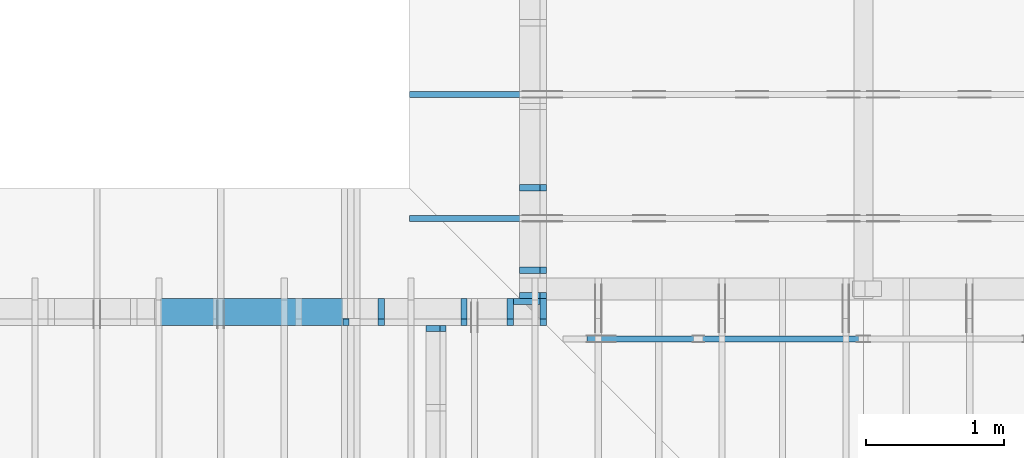
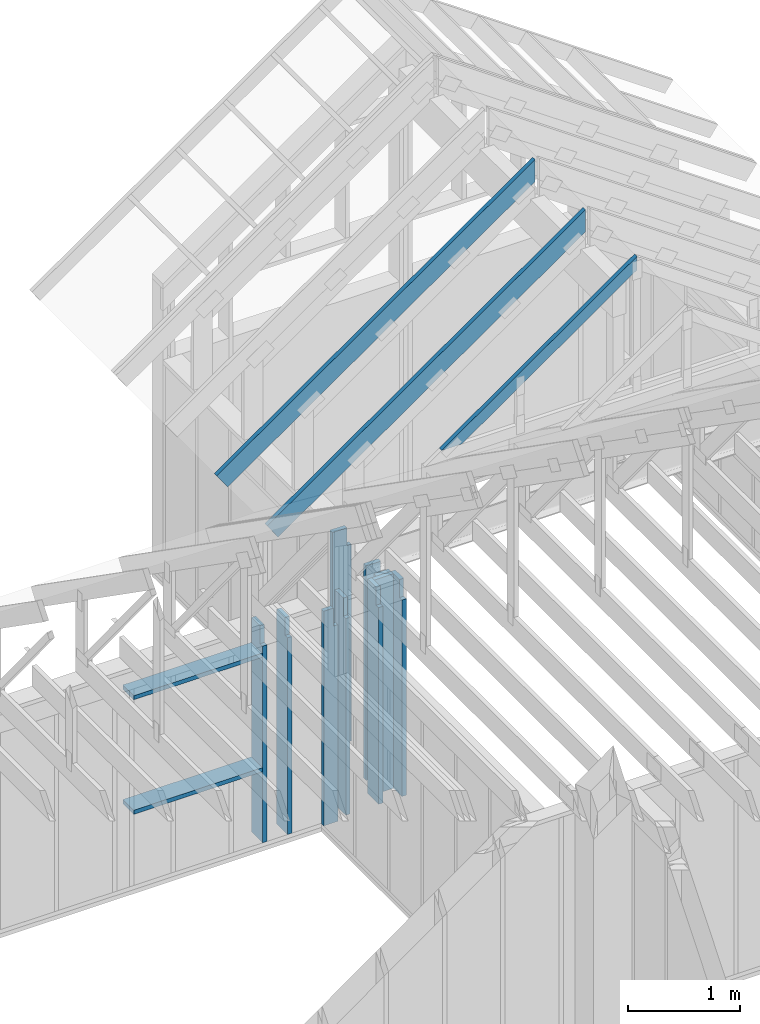
# One storey, part 30 of 70: 15 members, 6 elements without a shape of their own.
"""IFC2X3 building model written with IfcOpenShell, lengths in millimetres."""

from ifc_helpers import new_model, si_unit, frame, origin, origin_with_axes, origin_2d, place, context, project, spatial, faceted_brep, element, aggregate, save


model = new_model("IFC2X3")

# Units and contexts
model_context = context("Model", 3, precision=1e-05, world=origin())
plan_context = context("Plan", 2, precision=1e-05, world=origin_2d())
ifc_project = project(units=[si_unit("LENGTHUNIT", "METRE", prefix="MILLI"), si_unit("AREAUNIT", "SQUARE_METRE"), si_unit("VOLUMEUNIT", "CUBIC_METRE"), si_unit("SOLIDANGLEUNIT", "STERADIAN"), si_unit("PLANEANGLEUNIT", "RADIAN"), si_unit("MASSUNIT", "GRAM"), si_unit("TIMEUNIT", "SECOND"), si_unit("THERMODYNAMICTEMPERATUREUNIT", "DEGREE_CELSIUS"), si_unit("LUMINOUSINTENSITYUNIT", "LUMEN")], contexts=[model_context, plan_context])

# Site, building, storey
site_placement = place(None, origin_with_axes())
site = spatial("IfcSite", under=ifc_project, at=site_placement, CompositionType="ELEMENT")
building_placement = place(site_placement, origin_with_axes())
building = spatial("IfcBuilding", under=site, at=building_placement, Name="Layout 1", CompositionType="ELEMENT")
storey_placement = place(building_placement, origin_with_axes())
storey = spatial("IfcBuildingStorey", under=building, at=storey_placement, Name="Storey 1", CompositionType="ELEMENT", Elevation=0.0)

# Assembly, member
assembly_1_placement = place(storey_placement, frame((7000.0, 9505.0, 1.3776821480501744e-15), z_axis=(1.2246063538223773e-16, 1.0, 6.123031769111886e-17), x_axis=(-1.0, 1.2246063538223773e-16, 0.0)))
assembly_1 = element("IfcElementAssembly", 1, at=assembly_1_placement, inside=storey, Name="T4", AssemblyPlace="FACTORY", PredefinedType="TRUSS")
member_1_placement = place(assembly_1_placement, frame((-2589.347405088728, 2575.029527277477, -45.00000000000001), z_axis=(0.0, 0.0, 1.0), x_axis=(0.8191520442889916, -0.5735764363510465, 0.0)))
member_1 = element("IfcMember", 2, at=member_1_placement, Name="T11", context=model_context, shape_type="Brep", body=[
    faceted_brep([(4001.0887146659597, 194.99999999844545, 45.0), (0.0, 194.99999999844545, 45.0), (136.5404699499495, 1.8338823792873882e-09, 45.0), (4001.0887146652617, 1.8338823792873882e-09, 45.0), (0.0, 194.99999999844545, 0.0), (4001.0887146659597, 194.99999999844545, 4.899758662186943e-13), (4001.0887146652617, 1.8338823792873882e-09, 4.899758662186089e-13), (136.5404699499495, 1.8338823792873882e-09, 1.6720832705460153e-14), (136.54046994994948, 1.8338823792873882e-09, 7.888609052210118e-31), (136.54046994994948, 1.8338823792873882e-09, 45.0), (4.263256414560601e-14, 195.00000000048556, 45.0), (4.263256414560601e-14, 195.00000000048556, -3.1554436208840472e-30), (4001.0887146652617, 2.7584992468545714e-13, -1.6890378523536798e-29), (4001.0887146652617, 2.786052889815575e-13, 45.0), (136.5404699499495, 1.8338945482590892e-09, 45.0), (136.5404699499495, 1.833891792894793e-09, -5.763981720251638e-31), (4001.0887146652617, 194.99999999844545, -4.2712084852286463e-26), (4001.0887146652617, 194.99999999844545, 45.0), (4001.0887146652617, 0.0, 45.0), (4001.0887146652617, 0.0, 0.0), (0.0, 195.00000000048556, 0.0), (0.0, 195.00000000048556, 45.0), (4001.0887146659597, 194.9999999984455, 45.0), (4001.0887146659597, 194.9999999984455, 3.1554436208840472e-30)], [[[0, 1, 2, 3]], [[4, 5, 6, 7]], [[8, 9, 10, 11]], [[12, 13, 14, 15]], [[16, 17, 18, 19]], [[20, 21, 22, 23]]]),
])
aggregate(assembly_1, [member_1])

assembly_2_placement = place(storey_placement, frame((7000.0, 8605.0, 1.3776821480501744e-15), z_axis=(1.2246063538223773e-16, 1.0, 6.123031769111886e-17), x_axis=(-1.0, 1.2246063538223773e-16, 0.0)))
assembly_2 = element("IfcElementAssembly", 3, at=assembly_2_placement, inside=storey, Name="T4", AssemblyPlace="FACTORY", PredefinedType="TRUSS")
member_2_placement = place(assembly_2_placement, frame((-2589.347405088728, 2575.029527277477, -45.00000000000001), z_axis=(0.0, 0.0, 1.0), x_axis=(0.8191520442889916, -0.5735764363510465, 0.0)))
member_2 = element("IfcMember", 4, at=member_2_placement, Name="T11", context=model_context, shape_type="Brep", body=[
    faceted_brep([(4001.0887146659597, 194.99999999844545, 45.0), (0.0, 194.99999999844545, 45.0), (136.5404699499495, 1.8338823792873882e-09, 45.0), (4001.0887146652617, 1.8338823792873882e-09, 45.0), (0.0, 194.99999999844545, 0.0), (4001.0887146659597, 194.99999999844545, 4.899758662186943e-13), (4001.0887146652617, 1.8338823792873882e-09, 4.899758662186089e-13), (136.5404699499495, 1.8338823792873882e-09, 1.6720832705460153e-14), (136.54046994994948, 1.8338823792873882e-09, 7.888609052210118e-31), (136.54046994994948, 1.8338823792873882e-09, 45.0), (4.263256414560601e-14, 195.00000000048556, 45.0), (4.263256414560601e-14, 195.00000000048556, -3.1554436208840472e-30), (4001.0887146652617, 2.7584992468545714e-13, -1.6890378523536798e-29), (4001.0887146652617, 2.786052889815575e-13, 45.0), (136.5404699499495, 1.8338945482590892e-09, 45.0), (136.5404699499495, 1.833891792894793e-09, -5.763981720251638e-31), (4001.0887146652617, 194.99999999844545, -4.2712084852286463e-26), (4001.0887146652617, 194.99999999844545, 45.0), (4001.0887146652617, 0.0, 45.0), (4001.0887146652617, 0.0, 0.0), (0.0, 195.00000000048556, 0.0), (0.0, 195.00000000048556, 45.0), (4001.0887146659597, 194.9999999984455, 45.0), (4001.0887146659597, 194.9999999984455, 3.1554436208840472e-30)], [[[0, 1, 2, 3]], [[4, 5, 6, 7]], [[8, 9, 10, 11]], [[12, 13, 14, 15]], [[16, 17, 18, 19]], [[20, 21, 22, 23]]]),
])
aggregate(assembly_2, [member_2])

# Assembly, members
assembly_3_placement = place(storey_placement, frame((7000.0, 11805.0, -2470.0), z_axis=(-1.0, 1.836909530733566e-16, 6.123031769111886e-17), x_axis=(-1.836909530733566e-16, -1.0, 0.0)))
assembly_3 = element("IfcElementAssembly", 5, at=assembly_3_placement, inside=storey, Name="VE1", AssemblyPlace="FACTORY", PredefinedType="NOTDEFINED")
member_3_placement = place(assembly_3_placement, frame((3759.9999999962747, 2425.0, -195.00000000000003), z_axis=(0.0, 0.0, 1.0), x_axis=(-1.836909530733566e-16, -1.0, 0.0)))
member_3 = element("IfcMember", 6, at=member_3_placement, Name="S11", context=model_context, shape_type="Brep", body=[
    faceted_brep([(0.0, 45.0, 45.00000000000003), (195.00000000186265, 45.0, 45.00000000000005), (195.00000000186265, 0.0, 45.00000000000005), (0.0, 0.0, 45.00000000000003), (195.00000000186265, 1.5552359400317073e-10, 2.842170943040401e-14), (195.00000000186265, 1.5552359400317073e-10, 45.00000000000003), (195.00000000186265, 45.000000000155524, 45.00000000000003), (195.00000000186265, 45.000000000155524, 2.842170943040401e-14), (2.7553642961003504e-15, -3.3742366240998114e-31, 45.00000000000003), (1.193991194976818e-14, -1.4621692037765842e-30, 195.00000000000003), (1.7450640541968876e-14, 45.0, 195.00000000000003), (8.266092888301048e-15, 45.0, 45.00000000000003), (2335.0, -4.2891837542628763e-13, 2.842170943040403e-14), (2335.0, -4.1697846347651946e-13, 195.00000000000003), (2.1932538056648764e-30, 1.193991194976818e-14, 195.00000000000003), (5.061354936149717e-31, 2.7553642961003504e-15, 45.00000000000003), (195.00000000186265, -3.306437155354634e-14, 45.00000000000003), (195.00000000186265, -3.5819735849646686e-14, 2.842170943040401e-14), (-1.6871183120499057e-31, 45.000000000155524, 45.00000000000003), (-7.310846018882921e-31, 45.00000000015551, 195.00000000000003), (2335.0, 45.00000000015537, 195.00000000000003), (2335.0, 45.00000000015538, 2.8421709430403998e-14), (195.00000000186265, 45.00000000015551, 2.842170943040401e-14), (195.00000000186265, 45.00000000015551, 45.00000000000003), (2335.0, 45.0000000018631, 0.0), (2335.0, 45.0000000018631, 195.00000000000003), (2335.0, 1.8630998965818435e-09, 195.00000000000003), (2335.0, 1.8630998965818435e-09, 0.0), (2335.0, 45.0000000018631, 195.00000000000003), (0.0, 45.0000000018631, 195.00000000000003), (0.0, 0.0, 195.00000000000003), (2335.0, 0.0, 195.00000000000003), (195.00000000186265, 45.000000000155524, 5.2301533330168465e-14), (2335.0, 45.000000000155524, 3.143672930479291e-13), (2335.0, 1.8630998965818435e-09, 3.143672930479291e-13), (195.00000000186265, 1.8630998965818435e-09, 5.2301533330168465e-14)], [[[0, 1, 2, 3]], [[4, 5, 6, 7]], [[8, 9, 10, 11]], [[12, 13, 14, 15, 16, 17]], [[18, 19, 20, 21, 22, 23]], [[24, 25, 26, 27]], [[28, 29, 30, 31]], [[32, 33, 34, 35]]]),
])
member_4_placement = place(assembly_3_placement, frame((3577.5000000036816, 2425.0, -195.00000000000003), z_axis=(0.0, 0.0, 1.0), x_axis=(-1.836909530733566e-16, -1.0, 0.0)))
member_4 = element("IfcMember", 7, at=member_4_placement, Name="S11", context=model_context, shape_type="Brep", body=[
    faceted_brep([(0.0, 45.0, 45.00000000000003), (195.00000000186265, 45.0, 45.00000000000005), (195.00000000186265, 0.0, 45.00000000000005), (0.0, 0.0, 45.00000000000003), (195.00000000186265, -2.1311460639909362e-46, 2.842170943040401e-14), (195.00000000186265, -3.3742366240998114e-31, 45.00000000000003), (195.00000000186265, 45.0, 45.00000000000003), (195.00000000186265, 45.0, 2.842170943040401e-14), (2.7553642961003504e-15, -3.3742366240998114e-31, 45.00000000000003), (1.193991194976818e-14, -1.4621692037765842e-30, 195.00000000000003), (1.7450640541968876e-14, 45.0, 195.00000000000003), (8.266092888301048e-15, 45.0, 45.00000000000003), (2335.0, -4.2891837542628763e-13, 2.842170943040403e-14), (2335.0, -4.1697846347651946e-13, 195.00000000000003), (2.1932538056648764e-30, 1.193991194976818e-14, 195.00000000000003), (5.061354936149717e-31, 2.7553642961003504e-15, 45.00000000000003), (195.00000000186265, -3.306437155354634e-14, 45.00000000000003), (195.00000000186265, -3.5819735849646686e-14, 2.842170943040401e-14), (-1.6871183120499057e-31, 45.0, 45.00000000000003), (-7.310846018882921e-31, 44.999999999999986, 195.00000000000003), (2335.0, 44.999999999999844, 195.00000000000003), (2335.0, 44.99999999999986, 2.8421709430403998e-14), (195.00000000186265, 44.999999999999986, 2.842170943040401e-14), (195.00000000186265, 44.999999999999986, 45.00000000000003), (2335.0, 45.000000000000455, 0.0), (2335.0, 45.000000000000455, 195.00000000000003), (2335.0, 4.547473508864641e-13, 195.00000000000003), (2335.0, 4.547473508864641e-13, 0.0), (2335.0, 45.000000000000455, 195.00000000000003), (0.0, 45.000000000000455, 195.00000000000003), (0.0, 0.0, 195.00000000000003), (2335.0, 0.0, 195.00000000000003), (195.00000000186265, 45.0, 5.2301533330168465e-14), (2335.0, 45.0, 3.143672930479291e-13), (2335.0, 4.547473508864641e-13, 3.143672930479291e-13), (195.00000000186265, 4.547473508864641e-13, 5.2301533330168465e-14)], [[[0, 1, 2, 3]], [[4, 5, 6, 7]], [[8, 9, 10, 11]], [[12, 13, 14, 15, 16, 17]], [[18, 19, 20, 21, 22, 23]], [[24, 25, 26, 27]], [[28, 29, 30, 31]], [[32, 33, 34, 35]]]),
])
member_5_placement = place(assembly_3_placement, frame((2977.5000000036816, 2425.0, -195.00000000000003), z_axis=(0.0, 0.0, 1.0), x_axis=(-1.836909530733566e-16, -1.0, 0.0)))
member_5 = element("IfcMember", 8, at=member_5_placement, Name="S11", context=model_context, shape_type="Brep", body=[
    faceted_brep([(0.0, 45.0, 45.00000000000003), (195.00000000186265, 45.0, 45.00000000000005), (195.00000000186265, 0.0, 45.00000000000005), (0.0, 0.0, 45.00000000000003), (195.00000000186265, -2.1311460639909362e-46, 2.842170943040401e-14), (195.00000000186265, -3.3742366240998114e-31, 45.00000000000003), (195.00000000186265, 45.0, 45.00000000000003), (195.00000000186265, 45.0, 2.842170943040401e-14), (2.7553642961003504e-15, -3.3742366240998114e-31, 45.00000000000003), (1.193991194976818e-14, -1.4621692037765842e-30, 195.00000000000003), (1.7450640541968876e-14, 45.0, 195.00000000000003), (8.266092888301048e-15, 45.0, 45.00000000000003), (2335.0, -4.2891837542628763e-13, 2.842170943040403e-14), (2335.0, -4.1697846347651946e-13, 195.00000000000003), (2.1932538056648764e-30, 1.193991194976818e-14, 195.00000000000003), (5.061354936149717e-31, 2.7553642961003504e-15, 45.00000000000003), (195.00000000186265, -3.306437155354634e-14, 45.00000000000003), (195.00000000186265, -3.5819735849646686e-14, 2.842170943040401e-14), (-1.6871183120499057e-31, 45.0, 45.00000000000003), (-7.310846018882921e-31, 44.999999999999986, 195.00000000000003), (2335.0, 44.999999999999844, 195.00000000000003), (2335.0, 44.99999999999986, 2.8421709430403998e-14), (195.00000000186265, 44.999999999999986, 2.842170943040401e-14), (195.00000000186265, 44.999999999999986, 45.00000000000003), (2335.0, 45.000000000000455, 0.0), (2335.0, 45.000000000000455, 195.00000000000003), (2335.0, 4.547473508864641e-13, 195.00000000000003), (2335.0, 4.547473508864641e-13, 0.0), (2335.0, 45.000000000000455, 195.00000000000003), (0.0, 45.000000000000455, 195.00000000000003), (0.0, 0.0, 195.00000000000003), (2335.0, 0.0, 195.00000000000003), (195.00000000186265, 45.0, 5.2301533330168465e-14), (2335.0, 45.0, 3.143672930479291e-13), (2335.0, 4.547473508864641e-13, 3.143672930479291e-13), (195.00000000186265, 4.547473508864641e-13, 5.2301533330168465e-14)], [[[0, 1, 2, 3]], [[4, 5, 6, 7]], [[8, 9, 10, 11]], [[12, 13, 14, 15, 16, 17]], [[18, 19, 20, 21, 22, 23]], [[24, 25, 26, 27]], [[28, 29, 30, 31]], [[32, 33, 34, 35]]]),
])
aggregate(assembly_3, [member_3, member_4, member_5])

assembly_4_placement = place(storey_placement, frame((6999.999999999999, 8000.0, -2470.0), z_axis=(1.2246063538223773e-16, 1.0, 6.123031769111886e-17), x_axis=(-1.0, 1.2246063538223773e-16, 0.0)))
assembly_4 = element("IfcElementAssembly", 9, at=assembly_4_placement, inside=storey, Name="VE2", AssemblyPlace="FACTORY", PredefinedType="NOTDEFINED")
member_6_placement = place(assembly_4_placement, frame((-150.0, 90.00000000000088, -195.00000000000003), z_axis=(0.0, 0.0, 1.0), x_axis=(6.123031769111886e-17, 1.0, 0.0)))
member_6 = element("IfcMember", 10, at=member_6_placement, Name="S11", context=model_context, shape_type="Brep", body=[
    faceted_brep([(2139.9999999981364, 45.00000000000014, 2.842170943040401e-14), (2139.9999999981364, 45.00000000000014, 45.00000000000003), (2139.9999999981364, 1.4210854715202004e-13, 45.00000000000003), (2139.9999999981364, 1.4210854715202004e-13, 2.842170943040401e-14), (2139.9999999981364, 45.00000000000014, 45.00000000000029), (2334.999999999999, 45.00000000000014, 45.00000000000031), (2334.999999999999, 1.4210854715202004e-13, 45.00000000000031), (2139.9999999981364, 1.4210854715202004e-13, 45.00000000000029), (2.842170943040401e-14, 45.00000000000014, 2.842170943040401e-14), (2.842170943040401e-14, 45.00000000000013, 195.00000000000003), (2334.999999999999, 44.999999999999986, 195.00000000000003), (2334.999999999999, 44.99999999999999, 45.00000000000003), (2139.9999999981364, 45.00000000000001, 45.00000000000003), (2139.9999999981364, 45.000000000000014, 2.8421709430404e-14), (2.842170943040401e-14, 45.0, 2.8421709430404014e-14), (2139.9999999981364, 45.0, 2.9048746914816454e-13), (2139.9999999981364, 1.4210854715202004e-13, 2.9048746914816454e-13), (2.842170943040401e-14, 1.4210854715202004e-13, 2.8421709430404014e-14), (2.842170943040401e-14, 0.0, 0.0), (-2.9370765802089257e-15, 1.7766315360985582e-29, 195.00000000000003), (2.255766645524459e-14, 45.0, 195.00000000000003), (5.391645246585752e-14, 45.0, -4.7069801456157764e-31), (2334.999999999999, -2.840544639781671e-13, 45.00000000000003), (2334.999999999999, -2.7486991632449927e-13, 195.00000000000003), (2.842170943040401e-14, 1.5404845910178822e-13, 195.00000000000003), (2.842170943040401e-14, 1.4210854715202004e-13, 2.8421709430404004e-14), (2139.9999999981364, -2.5099009242462076e-13, 2.842170943040403e-14), (2139.9999999981364, -2.482347281285204e-13, 45.00000000000003), (2334.999999999999, 45.00000000000014, 45.00000000000003), (2334.999999999999, 45.00000000000014, 195.00000000000003), (2334.999999999999, 1.4210854715202004e-13, 195.00000000000003), (2334.999999999999, 1.4210854715202004e-13, 45.00000000000003), (2334.999999999999, 45.00000000000014, 195.00000000000003), (2.842170943040401e-14, 45.00000000000014, 195.00000000000003), (2.842170943040401e-14, 0.0, 195.00000000000003), (2334.999999999999, 0.0, 195.00000000000003)], [[[0, 1, 2, 3]], [[4, 5, 6, 7]], [[8, 9, 10, 11, 12, 13]], [[14, 15, 16, 17]], [[18, 19, 20, 21]], [[22, 23, 24, 25, 26, 27]], [[28, 29, 30, 31]], [[32, 33, 34, 35]]]),
])
member_7_placement = place(assembly_4_placement, frame((90.0, 90.0, -195.00000000000003), z_axis=(0.0, 0.0, 1.0), x_axis=(6.123031769111886e-17, 1.0, 0.0)))
member_7 = element("IfcMember", 11, at=member_7_placement, Name="S11", context=model_context, shape_type="Brep", body=[
    faceted_brep([(2139.9999999981374, 45.000000000000135, 2.842170943040401e-14), (2139.9999999981374, 45.000000000000135, 45.00000000000003), (2139.9999999981374, 1.4210854715202004e-13, 45.00000000000003), (2139.9999999981374, 1.4210854715202004e-13, 2.842170943040401e-14), (2139.9999999981374, 45.000000000000135, 45.00000000000029), (2335.0, 45.000000000000135, 45.00000000000031), (2335.0, 1.4210854715202004e-13, 45.00000000000031), (2139.9999999981374, 1.4210854715202004e-13, 45.00000000000029), (-1.0655730319954681e-46, 45.00000000000015, 2.842170943040401e-14), (-7.310846018882921e-31, 45.000000000000135, 195.00000000000003), (2335.0, 44.99999999999999, 195.00000000000003), (2335.0, 45.0, 45.00000000000003), (2139.9999999981374, 45.000000000000014, 45.00000000000003), (2139.9999999981374, 45.00000000000002, 2.8421709430404e-14), (0.0, 45.00000000000001, 2.842170943040401e-14), (2139.9999999981374, 45.00000000000001, 2.9048746914816464e-13), (2139.9999999981374, 1.4210854715202004e-13, 2.9048746914816464e-13), (0.0, 1.4210854715202004e-13, 2.842170943040401e-14), (0.0, 0.0, 0.0), (1.193991194976818e-14, -1.4621692037765842e-30, 195.00000000000003), (1.745064054196888e-14, 45.000000000000014, 195.00000000000003), (5.510728592200699e-15, 45.000000000000014, -3.37423662409981e-31), (2335.0, -1.2809944300270402e-13, 45.00000000000003), (2335.0, -1.189148953490362e-13, 195.00000000000003), (3.3451185691845497e-29, 3.1000348007725144e-13, 195.00000000000003), (3.125793188618062e-29, 2.9806356812748326e-13, 2.8421709430403995e-14), (2139.9999999981374, -9.503507144915769e-14, 2.842170943040402e-14), (2139.9999999981374, -9.227970715305734e-14, 45.00000000000003), (2335.0, 45.000000000000156, 45.00000000000003), (2335.0, 45.000000000000156, 195.00000000000003), (2335.0, 1.4210854715202004e-13, 195.00000000000003), (2335.0, 1.4210854715202004e-13, 45.00000000000003), (2335.0, 45.00000000000015, 195.00000000000003), (0.0, 45.00000000000015, 195.00000000000003), (0.0, 0.0, 195.00000000000003), (2335.0, 0.0, 195.00000000000003)], [[[0, 1, 2, 3]], [[4, 5, 6, 7]], [[8, 9, 10, 11, 12, 13]], [[14, 15, 16, 17]], [[18, 19, 20, 21]], [[22, 23, 24, 25, 26, 27]], [[28, 29, 30, 31]], [[32, 33, 34, 35]]]),
])
member_8_placement = place(assembly_4_placement, frame((45.0, 89.99999999999999, -45.0), z_axis=(0.0, 0.0, 1.0), x_axis=(6.123031769111886e-17, 1.0, 0.0)))
member_8 = element("IfcMember", 12, at=member_8_placement, Name="S34", context=model_context, shape_type="Brep", body=[
    faceted_brep([(2335.0, 195.00000000000014, 45.0), (0.0, 195.00000000000014, 45.0), (1.4210854715202004e-14, 0.0, 45.0), (2335.0, 0.0, 45.0), (0.0, 195.00000000000014, 0.0), (2335.0, 195.00000000000014, 2.859455836175251e-13), (2335.0, 0.0, 2.859455836175251e-13), (1.4210854715202004e-14, 0.0, 1.7402702977483063e-30), (1.4210854715202004e-14, 0.0, 0.0), (1.6966219011302353e-14, -3.3742366240998092e-31, 45.0), (4.084604291083871e-14, 195.0, 45.0), (3.809067861473836e-14, 195.0, -2.332304352650737e-30), (2335.0, -4.2891837542628763e-13, 3.4964159879651713e-29), (2335.0, -4.261630111301873e-13, 45.0), (1.4210854715202004e-14, 2.7553642961003453e-15, 45.0), (1.4210854715202004e-14, -3.4752807859654105e-30, 2.1279254659050334e-46), (2335.0, 195.00000000000014, 0.0), (2335.0, 195.00000000000014, 45.0), (2335.0, 1.4210854715202004e-13, 45.0), (2335.0, 1.4210854715202004e-13, 0.0), (0.0, 195.0, 0.0), (0.0, 195.0, 45.0), (2335.0, 195.00000000000037, 45.0), (2335.0, 195.00000000000037, 1.4199496293978212e-29)], [[[0, 1, 2, 3]], [[4, 5, 6, 7]], [[8, 9, 10, 11]], [[12, 13, 14, 15]], [[16, 17, 18, 19]], [[20, 21, 22, 23]]]),
])
member_9_placement = place(assembly_4_placement, frame((382.50000000181944, 2425.0, -195.0), z_axis=(0.0, 0.0, 1.0), x_axis=(-1.836909530733566e-16, -1.0, 0.0)))
member_9 = element("IfcMember", 13, at=member_9_placement, Name="S11", context=model_context, shape_type="Brep", body=[
    faceted_brep([(0.0, 45.0000000000141, 45.0), (195.00000000186265, 45.0000000000141, 45.00000000000002), (195.00000000186265, 1.4097167877480388e-11, 45.00000000000002), (0.0, 1.4097167877480388e-11, 45.0), (195.00000000186265, 1.2960299500264227e-11, 0.0), (195.00000000186265, 1.2960299500264227e-11, 45.0), (195.00000000186265, 45.000000000014154, 45.0), (195.00000000186265, 45.000000000014154, 0.0), (2.7553642961020753e-15, 1.4097167877480388e-11, 45.0), (1.1939911949769904e-14, 1.4097167877480388e-11, 195.0), (1.7450640541970602e-14, 45.0000000000141, 195.0), (8.266092888302773e-15, 45.0000000000141, 45.0), (2335.0, 1.36682495020541e-11, 2.626280839091018e-29), (2335.0, 1.3680189414003868e-11, 195.0), (2.193253805664876e-30, 1.4109107789430156e-11, 195.0), (5.061354936149714e-31, 1.4099923241776488e-11, 45.0), (195.00000000186265, 1.4064103505926841e-11, 45.0), (195.00000000186265, 1.406134814163074e-11, 2.193253805685862e-30), (-1.6871183120499046e-31, 45.000000000014154, 45.0), (-7.31084601888292e-31, 45.00000000001414, 195.0), (2335.0, 45.000000000014, 195.0), (2335.0, 45.00000000001401, -8.67746995743113e-30), (195.00000000186265, 45.00000000001414, -7.888609052210118e-31), (195.00000000186265, 45.00000000001414, 45.0), (2335.0, 45.00000000001455, 0.0), (2335.0, 45.00000000001455, 195.0), (2335.0, 0.0, 195.0), (2335.0, 0.0, 0.0), (2335.0, 45.00000000001455, 195.0), (0.0, 45.00000000001455, 195.0), (0.0, 1.4097167877480388e-11, 195.0), (2335.0, 1.4097167877480388e-11, 195.0), (195.00000000186265, 45.000000000014154, 2.3879823899764457e-14), (2335.0, 45.000000000014154, 2.859455836175251e-13), (2335.0, 0.0, 2.859455836175251e-13), (195.00000000186265, 0.0, 2.3879823899764457e-14)], [[[0, 1, 2, 3]], [[4, 5, 6, 7]], [[8, 9, 10, 11]], [[12, 13, 14, 15, 16, 17]], [[18, 19, 20, 21, 22, 23]], [[24, 25, 26, 27]], [[28, 29, 30, 31]], [[32, 33, 34, 35]]]),
])
member_10_placement = place(assembly_4_placement, frame((982.5000000018194, 2425.0, -195.0), z_axis=(0.0, 0.0, 1.0), x_axis=(-1.836909530733566e-16, -1.0, 0.0)))
member_10 = element("IfcMember", 14, at=member_10_placement, Name="S11", context=model_context, shape_type="Brep", body=[
    faceted_brep([(0.0, 45.0000000000141, 45.0), (195.00000000186265, 45.0000000000141, 45.00000000000002), (195.00000000186265, 1.4097167877480388e-11, 45.00000000000002), (0.0, 1.4097167877480388e-11, 45.0), (195.00000000186265, 1.2846612662542611e-11, 0.0), (195.00000000186265, 1.2846612662542611e-11, 45.0), (195.00000000186265, 45.0000000000141, 45.0), (195.00000000186265, 45.0000000000141, 0.0), (2.7553642961020753e-15, 1.4097167877480388e-11, 45.0), (1.1939911949769904e-14, 1.4097167877480388e-11, 195.0), (1.7450640541970602e-14, 45.0000000000141, 195.0), (8.266092888302773e-15, 45.0000000000141, 45.0), (2335.0, 1.36682495020541e-11, 2.626280839091018e-29), (2335.0, 1.3680189414003868e-11, 195.0), (2.193253805664876e-30, 1.4109107789430156e-11, 195.0), (5.061354936149714e-31, 1.4099923241776488e-11, 45.0), (195.00000000186265, 1.4064103505926841e-11, 45.0), (195.00000000186265, 1.406134814163074e-11, 2.193253805685862e-30), (-1.6871183120499046e-31, 45.0000000000141, 45.0), (-7.31084601888292e-31, 45.00000000001408, 195.0), (2335.0, 45.00000000001394, 195.0), (2335.0, 45.000000000013955, -8.67746995743113e-30), (195.00000000186265, 45.00000000001408, -7.888609052210118e-31), (195.00000000186265, 45.00000000001408, 45.0), (2335.0, 45.00000000001455, 0.0), (2335.0, 45.00000000001455, 195.0), (2335.0, 0.0, 195.0), (2335.0, 0.0, 0.0), (2335.0, 45.00000000001455, 195.0), (0.0, 45.00000000001455, 195.0), (0.0, 1.4097167877480388e-11, 195.0), (2335.0, 1.4097167877480388e-11, 195.0), (195.00000000186265, 45.0000000000141, 2.3879823899764457e-14), (2335.0, 45.0000000000141, 2.859455836175251e-13), (2335.0, 0.0, 2.859455836175251e-13), (195.00000000186265, 0.0, 2.3879823899764457e-14)], [[[0, 1, 2, 3]], [[4, 5, 6, 7]], [[8, 9, 10, 11]], [[12, 13, 14, 15, 16, 17]], [[18, 19, 20, 21, 22, 23]], [[24, 25, 26, 27]], [[28, 29, 30, 31]], [[32, 33, 34, 35]]]),
])
member_11_placement = place(assembly_4_placement, frame((1240.0000000015425, 2425.0, -195.00000000000003), z_axis=(0.0, 0.0, 1.0), x_axis=(-1.836909530733566e-16, -1.0, 0.0)))
member_11 = element("IfcMember", 15, at=member_11_placement, Name="S11", context=model_context, shape_type="Brep", body=[
    faceted_brep([(0.0, 45.0, 45.00000000000003), (195.00000000186265, 45.0, 45.00000000000005), (195.00000000186265, 0.0, 45.00000000000005), (0.0, 0.0, 45.00000000000003), (195.00000000186265, -2.1311460639909362e-46, 2.842170943040401e-14), (195.00000000186265, -3.3742366240998114e-31, 45.00000000000003), (195.00000000186265, 45.0, 45.00000000000003), (195.00000000186265, 45.0, 2.842170943040401e-14), (2.7553642961003504e-15, -3.3742366240998114e-31, 45.00000000000003), (1.193991194976818e-14, -1.4621692037765842e-30, 195.00000000000003), (1.7450640541968876e-14, 45.0, 195.00000000000003), (8.266092888301048e-15, 45.0, 45.00000000000003), (2335.0, -4.2891837542628763e-13, 2.842170943040403e-14), (2335.0, -4.1697846347651946e-13, 195.00000000000003), (2.1932538056648764e-30, 1.193991194976818e-14, 195.00000000000003), (5.061354936149717e-31, 2.7553642961003504e-15, 45.00000000000003), (195.00000000186265, -3.306437155354634e-14, 45.00000000000003), (195.00000000186265, -3.5819735849646686e-14, 2.842170943040401e-14), (-1.6871183120499057e-31, 45.0, 45.00000000000003), (-7.310846018882921e-31, 44.999999999999986, 195.00000000000003), (2335.0, 44.999999999999844, 195.00000000000003), (2335.0, 44.99999999999986, 2.8421709430403998e-14), (195.00000000186265, 44.999999999999986, 2.842170943040401e-14), (195.00000000186265, 44.999999999999986, 45.00000000000003), (2335.0, 45.000000000000455, 0.0), (2335.0, 45.000000000000455, 195.00000000000003), (2335.0, 4.547473508864641e-13, 195.00000000000003), (2335.0, 4.547473508864641e-13, 0.0), (2335.0, 45.000000000000455, 195.00000000000003), (0.0, 45.000000000000455, 195.00000000000003), (0.0, 0.0, 195.00000000000003), (2335.0, 0.0, 195.00000000000003), (195.00000000186265, 45.0, 5.2301533330168465e-14), (2335.0, 45.0, 3.143672930479291e-13), (2335.0, 4.547473508864641e-13, 3.143672930479291e-13), (195.00000000186265, 4.547473508864641e-13, 5.2301533330168465e-14)], [[[0, 1, 2, 3]], [[4, 5, 6, 7]], [[8, 9, 10, 11]], [[12, 13, 14, 15, 16, 17]], [[18, 19, 20, 21, 22, 23]], [[24, 25, 26, 27]], [[28, 29, 30, 31]], [[32, 33, 34, 35]]]),
])
member_12_placement = place(assembly_4_placement, frame((2609.999999999999, 2154.9999999987776, -195.0), z_axis=(0.0, 0.0, 1.0), x_axis=(-1.0, 1.2246063538223773e-16, 0.0)))
member_12 = element("IfcMember", 16, at=member_12_placement, Name="S22", context=model_context, shape_type="Brep", body=[
    faceted_brep([(1325.0000000002917, 45.00000000001501, 195.0), (0.0, 45.00000000001501, 195.0), (0.0, 0.0, 195.0), (1325.0000000002917, 0.0, 195.0), (0.0, 45.00000000001501, 0.0), (1325.0000000002917, 45.00000000001501, 1.622603418815007e-13), (1325.0000000002917, 0.0, 1.622603418815007e-13), (0.0, 0.0, 0.0), (0.0, 0.0, 0.0), (1.1939911949768178e-14, -1.462169203776584e-30, 195.0), (1.745064054197066e-14, 45.00000000001455, 195.0), (5.51072859220248e-15, 45.00000000001455, -3.3742366241009005e-31), (1325.0000000002917, -2.4339051282225105e-13, 4.2747203187083677e-29), (1325.0000000002917, -2.3145060087248287e-13, 195.0), (2.193253805664876e-30, 1.1939911949768178e-14, 195.0), (0.0, 0.0, 0.0), (1325.0000000002917, 45.00000000001501, 0.0), (1325.0000000002917, 45.00000000001501, 195.0), (1325.0000000002917, 4.547473508864641e-13, 195.0), (1325.0000000002917, 4.547473508864641e-13, 0.0), (0.0, 45.00000000001455, 0.0), (3.1554436208840472e-30, 45.00000000001454, 195.0), (1325.0000000002917, 45.00000000001505, 195.0), (1325.0000000002917, 45.000000000015056, 3.1554436208840472e-30)], [[[0, 1, 2, 3]], [[4, 5, 6, 7]], [[8, 9, 10, 11]], [[12, 13, 14, 15]], [[16, 17, 18, 19]], [[20, 21, 22, 23]]]),
])
member_13_placement = place(assembly_4_placement, frame((1284.9999999997071, 863.1713847472129, -195.0), z_axis=(0.0, 0.0, 1.0), x_axis=(1.0, 0.0, 0.0)))
member_13 = element("IfcMember", 17, at=member_13_placement, Name="S22", context=model_context, shape_type="Brep", body=[
    faceted_brep([(1325.000000000292, 45.0, 195.0), (0.0, 45.0, 195.0), (0.0, 0.0, 195.0), (1325.000000000292, 0.0, 195.0), (0.0, 45.0, 0.0), (1325.000000000292, 45.0, 1.6226034188150073e-13), (1325.000000000292, 0.0, 1.6226034188150073e-13), (0.0, 0.0, 0.0), (0.0, 0.0, 0.0), (1.1939911949768178e-14, -1.462169203776584e-30, 195.0), (1.7450640541968876e-14, 45.0, 195.0), (5.510728592200698e-15, 45.0, -3.3742366240998092e-31), (1325.000000000292, -2.433905128222511e-13, 1.4902878423110775e-29), (1325.000000000292, -2.314506008724829e-13, 195.0), (2.193253805664876e-30, 1.1939911949768178e-14, 195.0), (0.0, 0.0, 0.0), (1325.000000000292, 45.0, 0.0), (1325.000000000292, 45.0, 195.0), (1325.000000000292, 0.0, 195.0), (1325.000000000292, 0.0, 0.0), (0.0, 45.0, 0.0), (-7.31084601888292e-31, 44.999999999999986, 195.0), (1325.000000000292, 44.99999999999991, 195.0), (1325.000000000292, 44.99999999999992, -5.127595883936577e-30)], [[[0, 1, 2, 3]], [[4, 5, 6, 7]], [[8, 9, 10, 11]], [[12, 13, 14, 15]], [[16, 17, 18, 19]], [[20, 21, 22, 23]]]),
])
aggregate(assembly_4, [member_6, member_7, member_8, member_9, member_10, member_11, member_12, member_13])

# Assembly, member
assembly_5_placement = place(storey_placement, frame((7294.999999999998, 7682.5, 1206.561223771864), z_axis=(0.0, -1.0, 6.123031769111886e-17), x_axis=(1.0, 0.0, 0.0)))
assembly_5 = element("IfcElementAssembly", 18, at=assembly_5_placement, inside=storey, Name="SB1", AssemblyPlace="FACTORY", PredefinedType="TRUSS")
member_14_placement = place(assembly_5_placement, frame((262.7069331696554, 37.456424294357205, -45.0), z_axis=(0.0, 0.0, 1.0), x_axis=(0.8191520442889916, 0.5735764363510464, 0.0)))
member_14 = element("IfcMember", 19, at=member_14_placement, Name="T19", context=model_context, shape_type="Brep", body=[
    faceted_brep([(2455.1269244994473, 120.00000000034447, 45.0), (0.0, 120.00000000034447, 45.0), (171.37776080961942, 4.362732397567015e-10, 45.0), (2371.102019914042, 4.362732397567015e-10, 45.0), (0.0, 120.00000000034447, 0.0), (2455.1269244994473, 120.00000000034447, 3.006564031182415e-13), (2371.102019914042, 4.362732397567015e-10, 2.903666599147809e-13), (171.37776080961942, 4.362732397567015e-10, 2.0987029479131154e-14), (171.37776080961933, 4.362021854831255e-10, 5.5220263365470826e-30), (171.37776080961933, 4.362021854831255e-10, 45.0), (1.4210854715202004e-14, 120.00000000083257, 45.0), (1.4210854715202004e-14, 120.00000000083257, -3.1554436208840472e-30), (2371.102019914042, 1.9774439940891487e-13, -1.2107952397446483e-29), (2371.102019914042, 2.0049976370501522e-13, 45.0), (171.37776080961942, 4.362902876280676e-10, 45.0), (171.37776080961942, 4.362875322637715e-10, -8.751347484982656e-31), (2455.1269244994483, 120.00000000034402, 5.048709793414476e-29), (2455.1269244994483, 120.00000000034402, 45.0), (2371.102019914043, -4.547473508864641e-13, 45.0), (2371.102019914043, -4.547473508864641e-13, 5.048709793414476e-29), (0.0, 120.00000000083254, 0.0), (0.0, 120.00000000083254, 45.0), (2455.1269244994473, 120.00000000034449, 45.0), (2455.1269244994473, 120.00000000034449, 0.0)], [[[0, 1, 2, 3]], [[4, 5, 6, 7]], [[8, 9, 10, 11]], [[12, 13, 14, 15]], [[16, 17, 18, 19]], [[20, 21, 22, 23]]]),
])
aggregate(assembly_5, [member_14])

assembly_6_placement = place(storey_placement, frame((6320.15185546875, 7805.0, -2470.0), z_axis=(-1.0, 1.836909530733566e-16, 6.123031769111886e-17), x_axis=(-1.836909530733566e-16, -1.0, 0.0)))
assembly_6 = element("IfcElementAssembly", 20, at=assembly_6_placement, inside=storey, Name="VE7", AssemblyPlace="FACTORY", PredefinedType="NOTDEFINED")
member_15_placement = place(assembly_6_placement, frame((45.0, 90.00000000000045, -145.0), z_axis=(0.0, 0.0, 1.0), x_axis=(6.123031769111886e-17, 1.0, 0.0)))
member_15 = element("IfcMember", 21, at=member_15_placement, Name="S42", context=model_context, shape_type="Brep", body=[
    faceted_brep([(2139.999999998137, 45.00000000000013, 0.0), (2139.999999998137, 45.00000000000013, 45.0), (2139.999999998137, 1.2789769243681803e-13, 45.0), (2139.999999998137, 1.2789769243681803e-13, 0.0), (2139.999999998137, 45.00000000000013, 45.00000000000026), (2334.9999999999995, 45.00000000000013, 45.000000000000284), (2334.9999999999995, 1.2789769243681803e-13, 45.000000000000284), (2139.999999998137, 1.2789769243681803e-13, 45.00000000000026), (1.2154326714572542e-63, 45.00000000000014, 0.0), (-5.436270116605248e-31, 45.000000000000135, 145.0), (2334.9999999999995, 44.99999999999999, 145.0), (2334.9999999999995, 44.99999999999999, 45.0), (2139.999999998137, 45.00000000000001, 45.0), (2139.999999998137, 45.000000000000014, -7.888609052210118e-30), (0.0, 45.0, 0.0), (2139.999999998137, 45.0, 2.620657597177606e-13), (2139.999999998137, 1.2789769243681803e-13, 2.620657597177606e-13), (0.0, 1.2789769243681803e-13, 0.0), (1.7402702977483063e-30, -2.1311460639909362e-46, 2.842170943040401e-14), (8.878396065212235e-15, -1.0872540233210496e-30, 145.0), (1.4389124657412933e-14, 44.99999999999999, 145.0), (5.510728592200697e-15, 44.99999999999999, -3.3742366240998084e-31), (2334.9999999999995, -2.9826531869336915e-13, 45.0), (2334.9999999999995, -2.9214228692425727e-13, 145.0), (1.6308810349815745e-30, 1.3677608850203027e-13, 145.0), (0.0, 1.2789769243681803e-13, 0.0), (2139.999999998137, -2.652009471398228e-13, 2.4069554585224354e-29), (2139.999999998137, -2.6244558284372247e-13, 45.0), (2334.9999999999995, 45.00000000000014, 45.0), (2334.9999999999995, 45.00000000000014, 145.0), (2334.9999999999995, 1.3500311979441904e-13, 145.0), (2334.9999999999995, 1.3500311979441904e-13, 45.0), (2334.9999999999995, 45.00000000000014, 145.0), (0.0, 45.00000000000014, 145.0), (0.0, 0.0, 145.0), (2334.9999999999995, 0.0, 145.0)], [[[0, 1, 2, 3]], [[4, 5, 6, 7]], [[8, 9, 10, 11, 12, 13]], [[14, 15, 16, 17]], [[18, 19, 20, 21]], [[22, 23, 24, 25, 26, 27]], [[28, 29, 30, 31]], [[32, 33, 34, 35]]]),
])
aggregate(assembly_6, [member_15])

save(model, "model.ifc")
